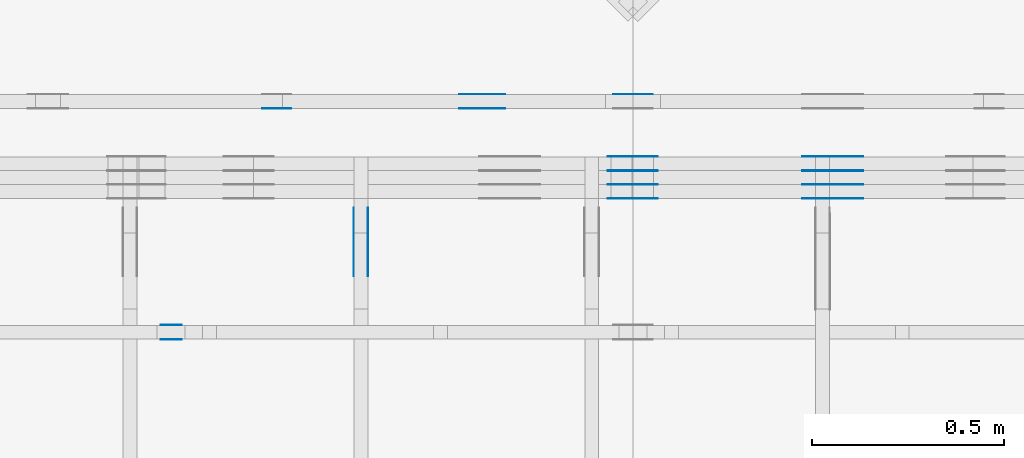
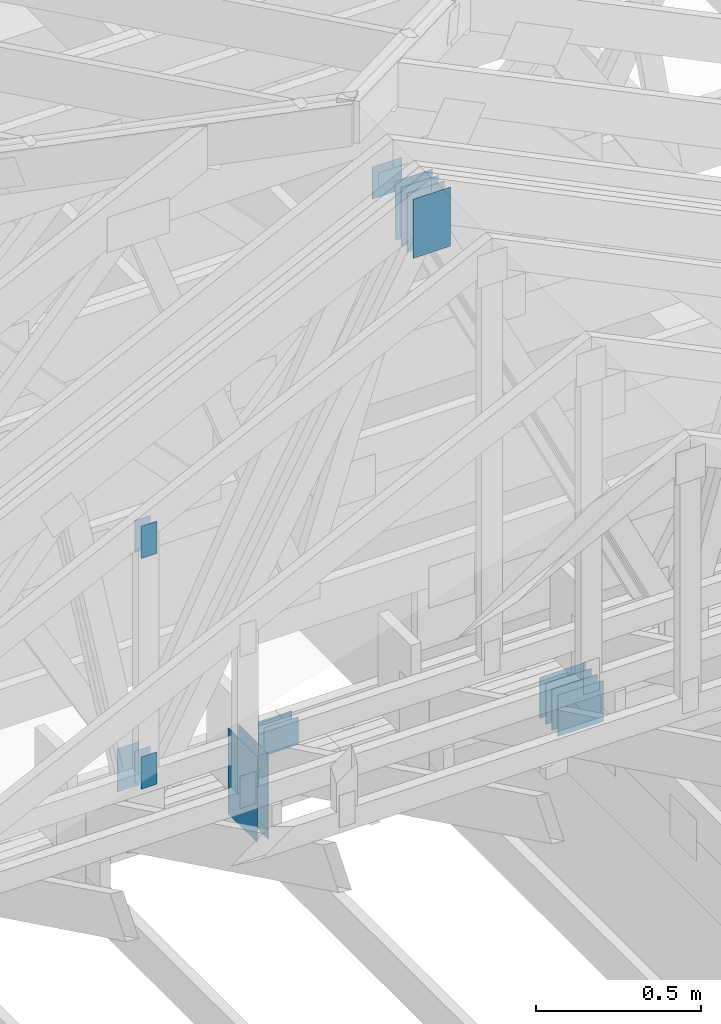
# One storey, part 103 of 159: 22 plates, 4 elements without a shape of their own.
"""IFC2X3 building model written with IfcOpenShell, lengths in millimetres."""

from ifc_helpers import new_model, si_unit, frame, origin, origin_with_axes, origin_2d, place, context, project, spatial, faceted_brep, element, aggregate, save


model = new_model("IFC2X3")

# Units and contexts
model_context = context("Model", 3, precision=1e-05, world=origin())
plan_context = context("Plan", 2, precision=1e-05, world=origin_2d())
ifc_project = project(units=[si_unit("LENGTHUNIT", "METRE", prefix="MILLI"), si_unit("AREAUNIT", "SQUARE_METRE"), si_unit("VOLUMEUNIT", "CUBIC_METRE"), si_unit("SOLIDANGLEUNIT", "STERADIAN"), si_unit("PLANEANGLEUNIT", "RADIAN"), si_unit("MASSUNIT", "GRAM"), si_unit("TIMEUNIT", "SECOND"), si_unit("THERMODYNAMICTEMPERATUREUNIT", "DEGREE_CELSIUS"), si_unit("LUMINOUSINTENSITYUNIT", "LUMEN")], contexts=[model_context, plan_context])

# Site, building, storey
site_placement = place(None, origin_with_axes())
site = spatial("IfcSite", under=ifc_project, at=site_placement, CompositionType="ELEMENT")
building_placement = place(site_placement, origin_with_axes())
building = spatial("IfcBuilding", under=site, at=building_placement, Name="Plan 1", CompositionType="ELEMENT")
storey_placement = place(building_placement, origin_with_axes())
storey = spatial("IfcBuildingStorey", under=building, at=storey_placement, Name="Etasje 1", CompositionType="ELEMENT", Elevation=0.0)

# Assembly, plates
assembly_1_placement = place(storey_placement, frame((10700.012663101485, 8801.999999990367, 0.0), z_axis=(0.0, -1.0, 6.123031769111886e-17), x_axis=(1.0, 0.0, 0.0)))
assembly_1 = element("IfcElementAssembly", 1, at=assembly_1_placement, inside=storey, Name="T8 (1)", AssemblyPlace="FACTORY", PredefinedType="TRUSS")
plate_1_placement = place(assembly_1_placement, frame((4340.0, 146.99999999999977, 0.0), z_axis=(0.0, 0.0, 1.0), x_axis=(1.0, 0.0, 0.0)))
plate_1 = element("IfcPlate", 2, at=plate_1_placement, Name="GNT100S 152x159", context=model_context, shape_type="Brep", body=[
    faceted_brep([(159.0, 152.00000000000023, 1.0), (0.0, 152.00000000000023, 1.0), (0.0, 2.2737367544323206e-13, 1.0), (159.0, 2.2737367544323206e-13, 1.0), (0.0, 152.00000000000023, 0.0), (159.0, 152.00000000000023, 1.9471241025775798e-14), (159.0, 2.2737367544323206e-13, 1.9471241025775798e-14), (0.0, 2.2737367544323206e-13, 0.0), (159.0, -2.92068615386637e-14, 1.788345410772899e-30), (159.0, -2.914563122097258e-14, 1.0), (1.1247455413666031e-32, 6.123031769111886e-17, 1.0), (0.0, 0.0, 0.0), (159.0, 152.0, 0.0), (159.0, 152.0, 1.0), (159.0, 0.0, 1.0), (159.0, 0.0, 0.0), (0.0, 152.0, 0.0), (-3.7491518045553436e-33, 152.0, 1.0), (159.0, 152.0, 1.0), (159.0, 152.0, 0.0), (0.0, 0.0, 0.0), (6.123031769111886e-17, -7.498303609110687e-33, 1.0), (1.8675246895791253e-14, 152.0, 1.0), (1.8614016578100134e-14, 152.0, -1.1397421485848245e-30)], [[[0, 1, 2, 3]], [[4, 5, 6, 7]], [[8, 9, 10, 11]], [[12, 13, 14, 15]], [[16, 17, 18, 19]], [[20, 21, 22, 23]]]),
])
plate_2_placement = place(assembly_1_placement, frame((4340.0, 146.99999999999977, -37.0), z_axis=(0.0, 0.0, 1.0), x_axis=(1.0, 0.0, 0.0)))
plate_2 = element("IfcPlate", 3, at=plate_2_placement, Name="GNT100S 152x159", context=model_context, shape_type="Brep", body=[
    faceted_brep([(159.0, 152.00000000000023, 1.0), (0.0, 152.00000000000023, 1.0), (0.0, 2.2737367544323206e-13, 1.0), (159.0, 2.2737367544323206e-13, 1.0), (0.0, 152.00000000000023, 0.0), (159.0, 152.00000000000023, 1.9471241025775798e-14), (159.0, 2.2737367544323206e-13, 1.9471241025775798e-14), (0.0, 2.2737367544323206e-13, 0.0), (159.0, -2.92068615386637e-14, 1.788345410772899e-30), (159.0, -2.914563122097258e-14, 1.0), (1.1247455413666031e-32, 6.123031769111886e-17, 1.0), (0.0, 0.0, 0.0), (159.0, 152.0, 0.0), (159.0, 152.0, 1.0), (159.0, 0.0, 1.0), (159.0, 0.0, 0.0), (0.0, 152.0, 0.0), (-3.7491518045553436e-33, 152.0, 1.0), (159.0, 152.0, 1.0), (159.0, 152.0, 0.0), (0.0, 0.0, 0.0), (6.123031769111886e-17, -7.498303609110687e-33, 1.0), (1.8675246895791253e-14, 152.0, 1.0), (1.8614016578100134e-14, 152.0, -1.1397421485848245e-30)], [[[0, 1, 2, 3]], [[4, 5, 6, 7]], [[8, 9, 10, 11]], [[12, 13, 14, 15]], [[16, 17, 18, 19]], [[20, 21, 22, 23]]]),
])
plate_3_placement = place(assembly_1_placement, frame((4340.0, 146.99999999999977, -36.0), z_axis=(0.0, 0.0, 1.0), x_axis=(1.0, 0.0, 0.0)))
plate_3 = element("IfcPlate", 4, at=plate_3_placement, Name="GNT100S 152x159", context=model_context, shape_type="Brep", body=[
    faceted_brep([(159.0, 152.00000000000023, 1.0), (0.0, 152.00000000000023, 1.0), (0.0, 2.2737367544323206e-13, 1.0), (159.0, 2.2737367544323206e-13, 1.0), (0.0, 152.00000000000023, 0.0), (159.0, 152.00000000000023, 1.9471241025775798e-14), (159.0, 2.2737367544323206e-13, 1.9471241025775798e-14), (0.0, 2.2737367544323206e-13, 0.0), (159.0, -2.92068615386637e-14, 1.788345410772899e-30), (159.0, -2.914563122097258e-14, 1.0), (1.1247455413666031e-32, 6.123031769111886e-17, 1.0), (0.0, 0.0, 0.0), (159.0, 152.0, 0.0), (159.0, 152.0, 1.0), (159.0, 0.0, 1.0), (159.0, 0.0, 0.0), (0.0, 152.0, 0.0), (-3.7491518045553436e-33, 152.0, 1.0), (159.0, 152.0, 1.0), (159.0, 152.0, 0.0), (0.0, 0.0, 0.0), (6.123031769111886e-17, -7.498303609110687e-33, 1.0), (1.8675246895791253e-14, 152.0, 1.0), (1.8614016578100134e-14, 152.0, -1.1397421485848245e-30)], [[[0, 1, 2, 3]], [[4, 5, 6, 7]], [[8, 9, 10, 11]], [[12, 13, 14, 15]], [[16, 17, 18, 19]], [[20, 21, 22, 23]]]),
])
plate_4_placement = place(assembly_1_placement, frame((4340.0, 146.99999999999977, -73.0), z_axis=(0.0, 0.0, 1.0), x_axis=(1.0, 0.0, 0.0)))
plate_4 = element("IfcPlate", 5, at=plate_4_placement, Name="GNT100S 152x159", context=model_context, shape_type="Brep", body=[
    faceted_brep([(159.0, 152.00000000000023, 1.0), (0.0, 152.00000000000023, 1.0), (0.0, 2.2737367544323206e-13, 1.0), (159.0, 2.2737367544323206e-13, 1.0), (0.0, 152.00000000000023, 0.0), (159.0, 152.00000000000023, 1.9471241025775798e-14), (159.0, 2.2737367544323206e-13, 1.9471241025775798e-14), (0.0, 2.2737367544323206e-13, 0.0), (159.0, -2.92068615386637e-14, 1.788345410772899e-30), (159.0, -2.914563122097258e-14, 1.0), (1.1247455413666031e-32, 6.123031769111886e-17, 1.0), (0.0, 0.0, 0.0), (159.0, 152.0, 0.0), (159.0, 152.0, 1.0), (159.0, 0.0, 1.0), (159.0, 0.0, 0.0), (0.0, 152.0, 0.0), (-3.7491518045553436e-33, 152.0, 1.0), (159.0, 152.0, 1.0), (159.0, 152.0, 0.0), (0.0, 0.0, 0.0), (6.123031769111886e-17, -7.498303609110687e-33, 1.0), (1.8675246895791253e-14, 152.0, 1.0), (1.8614016578100134e-14, 152.0, -1.1397421485848245e-30)], [[[0, 1, 2, 3]], [[4, 5, 6, 7]], [[8, 9, 10, 11]], [[12, 13, 14, 15]], [[16, 17, 18, 19]], [[20, 21, 22, 23]]]),
])
plate_5_placement = place(assembly_1_placement, frame((4340.0, 146.99999999999977, -72.0), z_axis=(0.0, 0.0, 1.0), x_axis=(1.0, 0.0, 0.0)))
plate_5 = element("IfcPlate", 6, at=plate_5_placement, Name="GNT100S 152x159", context=model_context, shape_type="Brep", body=[
    faceted_brep([(159.0, 152.00000000000023, 1.0), (0.0, 152.00000000000023, 1.0), (0.0, 2.2737367544323206e-13, 1.0), (159.0, 2.2737367544323206e-13, 1.0), (0.0, 152.00000000000023, 0.0), (159.0, 152.00000000000023, 1.9471241025775798e-14), (159.0, 2.2737367544323206e-13, 1.9471241025775798e-14), (0.0, 2.2737367544323206e-13, 0.0), (159.0, -2.92068615386637e-14, 1.788345410772899e-30), (159.0, -2.914563122097258e-14, 1.0), (1.1247455413666031e-32, 6.123031769111886e-17, 1.0), (0.0, 0.0, 0.0), (159.0, 152.0, 0.0), (159.0, 152.0, 1.0), (159.0, 0.0, 1.0), (159.0, 0.0, 0.0), (0.0, 152.0, 0.0), (-3.7491518045553436e-33, 152.0, 1.0), (159.0, 152.0, 1.0), (159.0, 152.0, 0.0), (0.0, 0.0, 0.0), (6.123031769111886e-17, -7.498303609110687e-33, 1.0), (1.8675246895791253e-14, 152.0, 1.0), (1.8614016578100134e-14, 152.0, -1.1397421485848245e-30)], [[[0, 1, 2, 3]], [[4, 5, 6, 7]], [[8, 9, 10, 11]], [[12, 13, 14, 15]], [[16, 17, 18, 19]], [[20, 21, 22, 23]]]),
])
plate_6_placement = place(assembly_1_placement, frame((4340.0, 146.99999999999977, -109.0), z_axis=(0.0, 0.0, 1.0), x_axis=(1.0, 0.0, 0.0)))
plate_6 = element("IfcPlate", 7, at=plate_6_placement, Name="GNT100S 152x159", context=model_context, shape_type="Brep", body=[
    faceted_brep([(159.0, 152.00000000000023, 1.0), (0.0, 152.00000000000023, 1.0), (0.0, 2.2737367544323206e-13, 1.0), (159.0, 2.2737367544323206e-13, 1.0), (0.0, 152.00000000000023, 0.0), (159.0, 152.00000000000023, 1.9471241025775798e-14), (159.0, 2.2737367544323206e-13, 1.9471241025775798e-14), (0.0, 2.2737367544323206e-13, 0.0), (159.0, -2.92068615386637e-14, 1.788345410772899e-30), (159.0, -2.914563122097258e-14, 1.0), (1.1247455413666031e-32, 6.123031769111886e-17, 1.0), (0.0, 0.0, 0.0), (159.0, 152.0, 0.0), (159.0, 152.0, 1.0), (159.0, 0.0, 1.0), (159.0, 0.0, 0.0), (0.0, 152.0, 0.0), (-3.7491518045553436e-33, 152.0, 1.0), (159.0, 152.0, 1.0), (159.0, 152.0, 0.0), (0.0, 0.0, 0.0), (6.123031769111886e-17, -7.498303609110687e-33, 1.0), (1.8675246895791253e-14, 152.0, 1.0), (1.8614016578100134e-14, 152.0, -1.1397421485848245e-30)], [[[0, 1, 2, 3]], [[4, 5, 6, 7]], [[8, 9, 10, 11]], [[12, 13, 14, 15]], [[16, 17, 18, 19]], [[20, 21, 22, 23]]]),
])
plate_7_placement = place(assembly_1_placement, frame((3834.999999999998, 2307.9048202130944, 0.0), z_axis=(0.0, 0.0, 1.0), x_axis=(6.123031769111886e-17, -1.0, 0.0)))
plate_7 = element("IfcPlate", 8, at=plate_7_placement, Name="GNT100S 130x218", context=model_context, shape_type="Brep", body=[
    faceted_brep([(218.00003505684435, 130.00000000000182, 1.0), (3.505684435367584e-05, 130.00000000000182, 1.0), (3.505684435367584e-05, 1.8189894035458565e-12, 1.0), (218.00003505684435, 1.8189894035458565e-12, 1.0), (3.505684435367584e-05, 130.00000000000182, 4.293083434047357e-21), (218.00003505684435, 130.00000000000182, 2.6696422806411258e-14), (218.00003505684435, 1.8189894035458565e-12, 2.6696422806411258e-14), (3.505684435367584e-05, 1.8189894035458565e-12, 4.293083434047357e-21), (218.0, -4.0044627769991736e-14, 2.4519452801791947e-30), (218.0, -3.998339745230062e-14, 1.0), (1.1247455413666031e-32, 6.123031769111886e-17, 1.0), (0.0, 0.0, 0.0), (218.0, 130.0, 0.0), (218.0, 130.0, 1.0), (218.0, 0.0, 1.0), (218.0, 0.0, 0.0), (0.0, 130.0, 0.0), (-3.7491518045553436e-33, 130.0, 1.0), (218.0, 130.0, 1.0), (218.0, 130.0, -1.5777218104420236e-30), (0.0, 0.0, 0.0), (6.123031769111886e-17, -7.498303609110687e-33, 1.0), (1.5981112917382023e-14, 130.0, 1.0), (1.5919882599690904e-14, 130.0, -9.747794691843893e-31)], [[[0, 1, 2, 3]], [[4, 5, 6, 7]], [[8, 9, 10, 11]], [[12, 13, 14, 15]], [[16, 17, 18, 19]], [[20, 21, 22, 23]]]),
])
plate_8_placement = place(assembly_1_placement, frame((3834.999999999998, 2307.9048202130944, -37.0), z_axis=(0.0, 0.0, 1.0), x_axis=(6.123031769111886e-17, -1.0, 0.0)))
plate_8 = element("IfcPlate", 9, at=plate_8_placement, Name="GNT100S 130x218", context=model_context, shape_type="Brep", body=[
    faceted_brep([(218.00003505684435, 130.00000000000182, 1.0), (3.505684435367584e-05, 130.00000000000182, 1.0), (3.505684435367584e-05, 1.8189894035458565e-12, 1.0), (218.00003505684435, 1.8189894035458565e-12, 1.0), (3.505684435367584e-05, 130.00000000000182, 4.293083434047357e-21), (218.00003505684435, 130.00000000000182, 2.6696422806411258e-14), (218.00003505684435, 1.8189894035458565e-12, 2.6696422806411258e-14), (3.505684435367584e-05, 1.8189894035458565e-12, 4.293083434047357e-21), (218.0, -4.0044627769991736e-14, 2.4519452801791947e-30), (218.0, -3.998339745230062e-14, 1.0), (1.1247455413666031e-32, 6.123031769111886e-17, 1.0), (0.0, 0.0, 0.0), (218.0, 130.0, 0.0), (218.0, 130.0, 1.0), (218.0, 0.0, 1.0), (218.0, 0.0, 0.0), (0.0, 130.0, 0.0), (-3.7491518045553436e-33, 130.0, 1.0), (218.0, 130.0, 1.0), (218.0, 130.0, -1.5777218104420236e-30), (0.0, 0.0, 0.0), (6.123031769111886e-17, -7.498303609110687e-33, 1.0), (1.5981112917382023e-14, 130.0, 1.0), (1.5919882599690904e-14, 130.0, -9.747794691843893e-31)], [[[0, 1, 2, 3]], [[4, 5, 6, 7]], [[8, 9, 10, 11]], [[12, 13, 14, 15]], [[16, 17, 18, 19]], [[20, 21, 22, 23]]]),
])
plate_9_placement = place(assembly_1_placement, frame((3834.999999999998, 2307.9048202130944, -36.0), z_axis=(0.0, 0.0, 1.0), x_axis=(6.123031769111886e-17, -1.0, 0.0)))
plate_9 = element("IfcPlate", 10, at=plate_9_placement, Name="GNT100S 130x218", context=model_context, shape_type="Brep", body=[
    faceted_brep([(218.00003505684435, 130.00000000000182, 1.0), (3.505684435367584e-05, 130.00000000000182, 1.0), (3.505684435367584e-05, 1.8189894035458565e-12, 1.0), (218.00003505684435, 1.8189894035458565e-12, 1.0), (3.505684435367584e-05, 130.00000000000182, 4.293083434047357e-21), (218.00003505684435, 130.00000000000182, 2.6696422806411258e-14), (218.00003505684435, 1.8189894035458565e-12, 2.6696422806411258e-14), (3.505684435367584e-05, 1.8189894035458565e-12, 4.293083434047357e-21), (218.0, -4.0044627769991736e-14, 2.4519452801791947e-30), (218.0, -3.998339745230062e-14, 1.0), (1.1247455413666031e-32, 6.123031769111886e-17, 1.0), (0.0, 0.0, 0.0), (218.0, 130.0, 0.0), (218.0, 130.0, 1.0), (218.0, 0.0, 1.0), (218.0, 0.0, 0.0), (0.0, 130.0, 0.0), (-3.7491518045553436e-33, 130.0, 1.0), (218.0, 130.0, 1.0), (218.0, 130.0, -1.5777218104420236e-30), (0.0, 0.0, 0.0), (6.123031769111886e-17, -7.498303609110687e-33, 1.0), (1.5981112917382023e-14, 130.0, 1.0), (1.5919882599690904e-14, 130.0, -9.747794691843893e-31)], [[[0, 1, 2, 3]], [[4, 5, 6, 7]], [[8, 9, 10, 11]], [[12, 13, 14, 15]], [[16, 17, 18, 19]], [[20, 21, 22, 23]]]),
])
plate_10_placement = place(assembly_1_placement, frame((3834.999999999998, 2307.9048202130944, -73.0), z_axis=(0.0, 0.0, 1.0), x_axis=(6.123031769111886e-17, -1.0, 0.0)))
plate_10 = element("IfcPlate", 11, at=plate_10_placement, Name="GNT100S 130x218", context=model_context, shape_type="Brep", body=[
    faceted_brep([(218.00003505684435, 130.00000000000182, 1.0), (3.505684435367584e-05, 130.00000000000182, 1.0), (3.505684435367584e-05, 1.8189894035458565e-12, 1.0), (218.00003505684435, 1.8189894035458565e-12, 1.0), (3.505684435367584e-05, 130.00000000000182, 4.293083434047357e-21), (218.00003505684435, 130.00000000000182, 2.6696422806411258e-14), (218.00003505684435, 1.8189894035458565e-12, 2.6696422806411258e-14), (3.505684435367584e-05, 1.8189894035458565e-12, 4.293083434047357e-21), (218.0, -4.0044627769991736e-14, 2.4519452801791947e-30), (218.0, -3.998339745230062e-14, 1.0), (1.1247455413666031e-32, 6.123031769111886e-17, 1.0), (0.0, 0.0, 0.0), (218.0, 130.0, 0.0), (218.0, 130.0, 1.0), (218.0, 0.0, 1.0), (218.0, 0.0, 0.0), (0.0, 130.0, 0.0), (-3.7491518045553436e-33, 130.0, 1.0), (218.0, 130.0, 1.0), (218.0, 130.0, -1.5777218104420236e-30), (0.0, 0.0, 0.0), (6.123031769111886e-17, -7.498303609110687e-33, 1.0), (1.5981112917382023e-14, 130.0, 1.0), (1.5919882599690904e-14, 130.0, -9.747794691843893e-31)], [[[0, 1, 2, 3]], [[4, 5, 6, 7]], [[8, 9, 10, 11]], [[12, 13, 14, 15]], [[16, 17, 18, 19]], [[20, 21, 22, 23]]]),
])
plate_11_placement = place(assembly_1_placement, frame((3834.999999999998, 2307.9048202130944, -72.0), z_axis=(0.0, 0.0, 1.0), x_axis=(6.123031769111886e-17, -1.0, 0.0)))
plate_11 = element("IfcPlate", 12, at=plate_11_placement, Name="GNT100S 130x218", context=model_context, shape_type="Brep", body=[
    faceted_brep([(218.00003505684435, 130.00000000000182, 1.0), (3.505684435367584e-05, 130.00000000000182, 1.0), (3.505684435367584e-05, 1.8189894035458565e-12, 1.0), (218.00003505684435, 1.8189894035458565e-12, 1.0), (3.505684435367584e-05, 130.00000000000182, 4.293083434047357e-21), (218.00003505684435, 130.00000000000182, 2.6696422806411258e-14), (218.00003505684435, 1.8189894035458565e-12, 2.6696422806411258e-14), (3.505684435367584e-05, 1.8189894035458565e-12, 4.293083434047357e-21), (218.0, -4.0044627769991736e-14, 2.4519452801791947e-30), (218.0, -3.998339745230062e-14, 1.0), (1.1247455413666031e-32, 6.123031769111886e-17, 1.0), (0.0, 0.0, 0.0), (218.0, 130.0, 0.0), (218.0, 130.0, 1.0), (218.0, 0.0, 1.0), (218.0, 0.0, 0.0), (0.0, 130.0, 0.0), (-3.7491518045553436e-33, 130.0, 1.0), (218.0, 130.0, 1.0), (218.0, 130.0, -1.5777218104420236e-30), (0.0, 0.0, 0.0), (6.123031769111886e-17, -7.498303609110687e-33, 1.0), (1.5981112917382023e-14, 130.0, 1.0), (1.5919882599690904e-14, 130.0, -9.747794691843893e-31)], [[[0, 1, 2, 3]], [[4, 5, 6, 7]], [[8, 9, 10, 11]], [[12, 13, 14, 15]], [[16, 17, 18, 19]], [[20, 21, 22, 23]]]),
])
plate_12_placement = place(assembly_1_placement, frame((3834.999999999998, 2307.9048202130944, -109.0), z_axis=(0.0, 0.0, 1.0), x_axis=(6.123031769111886e-17, -1.0, 0.0)))
plate_12 = element("IfcPlate", 13, at=plate_12_placement, Name="GNT100S 130x218", context=model_context, shape_type="Brep", body=[
    faceted_brep([(218.00003505684435, 130.00000000000182, 1.0), (3.505684435367584e-05, 130.00000000000182, 1.0), (3.505684435367584e-05, 1.8189894035458565e-12, 1.0), (218.00003505684435, 1.8189894035458565e-12, 1.0), (3.505684435367584e-05, 130.00000000000182, 4.293083434047357e-21), (218.00003505684435, 130.00000000000182, 2.6696422806411258e-14), (218.00003505684435, 1.8189894035458565e-12, 2.6696422806411258e-14), (3.505684435367584e-05, 1.8189894035458565e-12, 4.293083434047357e-21), (218.0, -4.0044627769991736e-14, 2.4519452801791947e-30), (218.0, -3.998339745230062e-14, 1.0), (1.1247455413666031e-32, 6.123031769111886e-17, 1.0), (0.0, 0.0, 0.0), (218.0, 130.0, 0.0), (218.0, 130.0, 1.0), (218.0, 0.0, 1.0), (218.0, 0.0, 0.0), (0.0, 130.0, 0.0), (-3.7491518045553436e-33, 130.0, 1.0), (218.0, 130.0, 1.0), (218.0, 130.0, -1.5777218104420236e-30), (0.0, 0.0, 0.0), (6.123031769111886e-17, -7.498303609110687e-33, 1.0), (1.5981112917382023e-14, 130.0, 1.0), (1.5919882599690904e-14, 130.0, -9.747794691843893e-31)], [[[0, 1, 2, 3]], [[4, 5, 6, 7]], [[8, 9, 10, 11]], [[12, 13, 14, 15]], [[16, 17, 18, 19]], [[20, 21, 22, 23]]]),
])
aggregate(assembly_1, [plate_1, plate_2, plate_3, plate_4, plate_5, plate_6, plate_7, plate_8, plate_9, plate_10, plate_11, plate_12])

assembly_2_placement = place(storey_placement, frame((10000.012663278096, 9072.000080051337, 1.1021457184401395e-15), z_axis=(9.811600543477555e-09, 1.0, 6.123031769111886e-17), x_axis=(-1.0, 9.811600543477555e-09, 0.0)))
assembly_2 = element("IfcElementAssembly", 14, at=assembly_2_placement, inside=storey, Name="T9 (79)", AssemblyPlace="FACTORY", PredefinedType="TRUSS")
plate_13_placement = place(assembly_2_placement, frame((-4651.5, 2258.4048202130944, 0.0), z_axis=(0.0, 0.0, 1.0), x_axis=(6.123031769111886e-17, -1.0, 0.0)))
plate_13 = element("IfcPlate", 15, at=plate_13_placement, Name="GNT100S 103x119", context=model_context, shape_type="Brep", body=[
    faceted_brep([(119.00003505684435, 103.0, 1.0), (3.505684435367584e-05, 103.0, 1.0), (3.505684435367584e-05, 0.0, 1.0), (119.00003505684435, 0.0, 1.0), (3.505684435367584e-05, 103.0, 4.293083434047357e-21), (119.00003505684435, 103.0, 1.4572819903569723e-14), (119.00003505684435, 0.0, 1.4572819903569723e-14), (3.505684435367584e-05, 0.0, 4.293083434047357e-21), (119.0, 1.797130180130127e-12, 1.3384471942262577e-30), (119.0, 1.7971914104478182e-12, 1.0), (1.1247455413666031e-32, 1.8190506338635476e-12, 1.0), (0.0, 1.8189894035458565e-12, 0.0), (119.0, 103.00000000000182, 0.0), (119.0, 103.00000000000182, 1.0), (119.0, 1.8189894035458565e-12, 1.0), (119.0, 1.8189894035458565e-12, 0.0), (0.0, 103.00000000000182, 0.0), (-3.7491518045553436e-33, 103.00000000000182, 1.0), (119.0, 103.0000000000018, 1.0), (119.0, 103.0000000000018, -7.888609052210118e-31), (2.227545981117832e-28, 1.8189894035458565e-12, -1.3639334809541992e-44), (6.123031769134162e-17, 1.8189894035458565e-12, 1.0), (1.2674675762061827e-14, 103.00000000000182, 1.0), (1.2613445444370708e-14, 103.00000000000182, -7.7232527173841444e-31)], [[[0, 1, 2, 3]], [[4, 5, 6, 7]], [[8, 9, 10, 11]], [[12, 13, 14, 15]], [[16, 17, 18, 19]], [[20, 21, 22, 23]]]),
])
plate_14_placement = place(assembly_2_placement, frame((-3636.319824218732, 291.5, -37.0), z_axis=(0.0, 0.0, 1.0), x_axis=(6.123031769111886e-17, 1.0, 0.0)))
plate_14 = element("IfcPlate", 16, at=plate_14_placement, Name="GNT100S 76x159", context=model_context, shape_type="Brep", body=[
    faceted_brep([(159.0, 76.00000000001819, 1.0), (0.0, 76.00000000001819, 1.0), (0.0, 1.8189894035458565e-11, 1.0), (159.0, 1.8189894035458565e-11, 1.0), (0.0, 76.00000000001819, 0.0), (159.0, 76.00000000001819, 1.9471241025775798e-14), (159.0, 1.8189894035458565e-11, 1.9471241025775798e-14), (0.0, 1.8189894035458565e-11, 0.0), (159.00000000000045, -2.920686153866378e-14, 1.788345410772904e-30), (159.00000000000045, -2.914563122097266e-14, 1.0), (4.547473508864641e-13, 6.123031769103533e-17, 1.0), (4.547473508864641e-13, -8.35329742919187e-29, 5.114750553578247e-45), (159.00000000000045, 76.0, 0.0), (159.00000000000045, 76.0, 1.0), (159.00000000000045, 0.0, 1.0), (159.00000000000045, 0.0, 0.0), (4.547473508864641e-13, 76.0, 0.0), (4.547473508864641e-13, 76.0, 1.0), (159.00000000000045, 75.99999999999999, 1.0), (159.00000000000045, 75.99999999999999, -7.888609052210118e-31), (4.547473508864641e-13, 0.0, 0.0), (4.548085812041552e-13, -7.498303609110687e-33, 1.0), (4.641155894932053e-13, 76.0, 1.0), (4.640543591755142e-13, 76.0, -5.698710742924122e-31)], [[[0, 1, 2, 3]], [[4, 5, 6, 7]], [[8, 9, 10, 11]], [[12, 13, 14, 15]], [[16, 17, 18, 19]], [[20, 21, 22, 23]]]),
])
plate_15_placement = place(assembly_2_placement, frame((-4149.3187043163925, 348.5000000000005, 0.0), z_axis=(0.0, 0.0, 1.0), x_axis=(-1.0, 1.2246063538223773e-16, 0.0)))
plate_15 = element("IfcPlate", 17, at=plate_15_placement, Name="GNT100S 103x119", context=model_context, shape_type="Brep", body=[
    faceted_brep([(119.00014333985746, 103.00000000000051, 1.0), (0.0001433398574590683, 103.00000000000051, 1.0), (0.0001433398574590683, 5.115907697472721e-13, 1.0), (119.00014333985746, 5.115907697472721e-13, 1.0), (0.0001433398574590683, 103.00000000000051, 1.755349002003689e-20), (119.00014333985746, 103.00000000000051, 1.457283316397631e-14), (119.00014333985746, 5.115907697472721e-13, 1.457283316397631e-14), (0.0001433398574590683, 5.115907697472721e-13, 1.755349002003689e-20), (119.0, -2.1859223415729434e-14, 1.3384471942262577e-30), (119.0, -2.1797993098038315e-14, 1.0), (1.1247455413666031e-32, 6.123031769111886e-17, 1.0), (0.0, 0.0, 0.0), (119.0, 103.0, 0.0), (119.0, 103.0, 1.0), (119.0, 0.0, 1.0), (119.0, 0.0, 0.0), (0.0, 103.0, 0.0), (-3.7491518045553436e-33, 103.0, 1.0), (119.0, 102.99999999999999, 1.0), (119.0, 102.99999999999999, -7.888609052210118e-31), (0.0, 0.0, 0.0), (6.123031769111886e-17, -7.498303609110687e-33, 1.0), (1.2674675762061605e-14, 103.0, 1.0), (1.2613445444370486e-14, 103.0, -7.723252717384008e-31)], [[[0, 1, 2, 3]], [[4, 5, 6, 7]], [[8, 9, 10, 11]], [[12, 13, 14, 15]], [[16, 17, 18, 19]], [[20, 21, 22, 23]]]),
])
plate_16_placement = place(assembly_2_placement, frame((-4149.3187043163925, 348.5000000000005, -37.0), z_axis=(0.0, 0.0, 1.0), x_axis=(-1.0, 1.2246063538223773e-16, 0.0)))
plate_16 = element("IfcPlate", 18, at=plate_16_placement, Name="GNT100S 103x119", context=model_context, shape_type="Brep", body=[
    faceted_brep([(119.00014333985746, 103.00000000000051, 1.0), (0.0001433398574590683, 103.00000000000051, 1.0), (0.0001433398574590683, 5.115907697472721e-13, 1.0), (119.00014333985746, 5.115907697472721e-13, 1.0), (0.0001433398574590683, 103.00000000000051, 1.755349002003689e-20), (119.00014333985746, 103.00000000000051, 1.457283316397631e-14), (119.00014333985746, 5.115907697472721e-13, 1.457283316397631e-14), (0.0001433398574590683, 5.115907697472721e-13, 1.755349002003689e-20), (119.0, -2.1859223415729434e-14, 1.3384471942262577e-30), (119.0, -2.1797993098038315e-14, 1.0), (1.1247455413666031e-32, 6.123031769111886e-17, 1.0), (0.0, 0.0, 0.0), (119.0, 103.0, 0.0), (119.0, 103.0, 1.0), (119.0, 0.0, 1.0), (119.0, 0.0, 0.0), (0.0, 103.0, 0.0), (-3.7491518045553436e-33, 103.0, 1.0), (119.0, 102.99999999999999, 1.0), (119.0, 102.99999999999999, -7.888609052210118e-31), (0.0, 0.0, 0.0), (6.123031769111886e-17, -7.498303609110687e-33, 1.0), (1.2674675762061605e-14, 103.0, 1.0), (1.2613445444370486e-14, 103.0, -7.723252717384008e-31)], [[[0, 1, 2, 3]], [[4, 5, 6, 7]], [[8, 9, 10, 11]], [[12, 13, 14, 15]], [[16, 17, 18, 19]], [[20, 21, 22, 23]]]),
])
aggregate(assembly_2, [plate_13, plate_14, plate_15, plate_16])

assembly_3_placement = place(storey_placement, frame((13875.022261404752, -699.9989301294836, 1.1021457184401395e-15), z_axis=(-1.0, 1.836909530733566e-16, 6.123031769111886e-17), x_axis=(-1.836909530733566e-16, -1.0, 0.0)))
assembly_3 = element("IfcElementAssembly", 19, at=assembly_3_placement, inside=storey, Name="T6 (101)", AssemblyPlace="FACTORY", PredefinedType="TRUSS")
plate_17_placement = place(assembly_3_placement, frame((-9477.154435624892, 601.947714222237, 0.0), z_axis=(0.0, 0.0, 1.0), x_axis=(2.6073089813474087e-12, -1.0, 0.0)))
plate_17 = element("IfcPlate", 20, at=plate_17_placement, Name="GNT100S 178x317", context=model_context, shape_type="Brep", body=[
    faceted_brep([(316.9999908340292, 178.00013874989236, 1.0), (2.1351607301767217e-05, 178.00013874989236, 1.0), (2.1351143232095637e-05, 0.00013874989235773683, 1.0), (316.99999083356505, 0.00013874989235773683, 1.0), (2.1351607301767217e-05, 178.00013874989236, 2.61473139660644e-21), (316.9999908340292, 178.00013874989236, 3.882002029369875e-14), (316.99999083356505, 0.0001387490647175582, 3.882002029364191e-14), (2.1351143232095637e-05, 0.0001387490647175582, 2.6146745663395966e-21), (317.00000000000006, -2.1010854189297505e-13, 1.286501276972462e-29), (317.00000000000006, -2.1004731157528393e-13, 1.0), (1.1368683772161603e-13, 1.8190506338635476e-12, 1.0), (1.1368683772161603e-13, 1.8189894035458565e-12, 0.0), (317.00000000000006, 178.0, 0.0), (317.00000000000006, 178.0, 1.0), (317.00000000000006, 0.0, 1.0), (317.00000000000006, 0.0, 0.0), (0.0, 178.00000000000182, 0.0), (0.0, 178.00000000000182, 1.0), (317.00000000000006, 177.99999999999997, 1.0), (317.00000000000006, 177.99999999999997, -1.5777218104420236e-30), (1.1368683772161664e-13, 1.8189894035458565e-12, -3.6433760072445244e-44), (1.1374806803930775e-13, 1.8189894035458565e-12, 1.0), (5.6498181784034924e-14, 178.00000000000182, 1.0), (5.6436951466343805e-14, 178.00000000000182, -3.455652467802488e-30)], [[[0, 1, 2, 3]], [[4, 5, 6, 7]], [[8, 9, 10, 11]], [[12, 13, 14, 15]], [[16, 17, 18, 19]], [[20, 21, 22, 23]]]),
])
plate_18_placement = place(assembly_3_placement, frame((-9477.154435624892, 601.947714222237, -37.0), z_axis=(0.0, 0.0, 1.0), x_axis=(2.6073089813474087e-12, -1.0, 0.0)))
plate_18 = element("IfcPlate", 21, at=plate_18_placement, Name="GNT100S 178x317", context=model_context, shape_type="Brep", body=[
    faceted_brep([(316.9999908340292, 178.00013874989236, 1.0), (2.1351607301767217e-05, 178.00013874989236, 1.0), (2.1351143232095637e-05, 0.00013874989235773683, 1.0), (316.99999083356505, 0.00013874989235773683, 1.0), (2.1351607301767217e-05, 178.00013874989236, 2.61473139660644e-21), (316.9999908340292, 178.00013874989236, 3.882002029369875e-14), (316.99999083356505, 0.0001387490647175582, 3.882002029364191e-14), (2.1351143232095637e-05, 0.0001387490647175582, 2.6146745663395966e-21), (317.00000000000006, -2.1010854189297505e-13, 1.286501276972462e-29), (317.00000000000006, -2.1004731157528393e-13, 1.0), (1.1368683772161603e-13, 1.8190506338635476e-12, 1.0), (1.1368683772161603e-13, 1.8189894035458565e-12, 0.0), (317.00000000000006, 178.0, 0.0), (317.00000000000006, 178.0, 1.0), (317.00000000000006, 0.0, 1.0), (317.00000000000006, 0.0, 0.0), (0.0, 178.00000000000182, 0.0), (0.0, 178.00000000000182, 1.0), (317.00000000000006, 177.99999999999997, 1.0), (317.00000000000006, 177.99999999999997, -1.5777218104420236e-30), (1.1368683772161664e-13, 1.8189894035458565e-12, -3.6433760072445244e-44), (1.1374806803930775e-13, 1.8189894035458565e-12, 1.0), (5.6498181784034924e-14, 178.00000000000182, 1.0), (5.6436951466343805e-14, 178.00000000000182, -3.455652467802488e-30)], [[[0, 1, 2, 3]], [[4, 5, 6, 7]], [[8, 9, 10, 11]], [[12, 13, 14, 15]], [[16, 17, 18, 19]], [[20, 21, 22, 23]]]),
])
aggregate(assembly_3, [plate_17, plate_18])

assembly_4_placement = place(storey_placement, frame((11246.01259527543, 8436.00006782605, 727.7147722720857), z_axis=(0.0, -1.0, 6.123031769111886e-17), x_axis=(1.0, 0.0, 0.0)))
assembly_4 = element("IfcElementAssembly", 22, at=assembly_4_placement, inside=storey, Name="Tr1 (1)", AssemblyPlace="FACTORY", PredefinedType="TRUSS")
plate_19_placement = place(assembly_4_placement, frame((2126.5, 1001.0410386863377, 0.0), z_axis=(0.0, 0.0, 1.0), x_axis=(6.123031769111886e-17, -1.0, 0.0)))
plate_19 = element("IfcPlate", 23, at=plate_19_placement, Name="GNT100S 55x119", context=model_context, shape_type="Brep", body=[
    faceted_brep([(119.00002306133774, 55.0, 1.0), (2.306133774254704e-05, 55.0, 1.0), (2.306133774254704e-05, 0.0, 1.0), (119.00002306133774, 0.0, 1.0), (2.306133774254704e-05, 55.0, 2.8241060727166902e-21), (119.00002306133774, 55.0, 1.4572818434592364e-14), (119.00002306133774, 0.0, 1.4572818434592364e-14), (2.306133774254704e-05, 0.0, 2.8241060727166902e-21), (119.0, 6.782605394252235e-05, 1.3384468320270608e-30), (119.0, 6.782605394258358e-05, 1.0), (1.1247455413666031e-32, 6.78260539644428e-05, 1.0), (0.0, 6.782605396438157e-05, 0.0), (119.0, 55.000067826053964, 0.0), (119.0, 55.000067826053964, 1.0), (119.0, 6.782605396438157e-05, 1.0), (119.0, 6.782605396438157e-05, 0.0), (2.4308653429145085e-63, 55.000067826053964, 0.0), (-3.7491518045553436e-33, 55.000067826053964, 1.0), (119.0, 55.00006782605396, 1.0), (119.0, 55.00006782605396, -3.944304526105059e-31), (8.306021663948111e-21, 6.782605396438157e-05, -5.085803452328586e-37), (6.123862371278281e-17, 6.782605396438157e-05, 1.0), (6.796573569735858e-15, 55.000067826053964, 1.0), (6.735343252044739e-15, 55.000067826053964, -4.12407207081433e-31)], [[[0, 1, 2, 3]], [[4, 5, 6, 7]], [[8, 9, 10, 11]], [[12, 13, 14, 15]], [[16, 17, 18, 19]], [[20, 21, 22, 23]]]),
])
plate_20_placement = place(assembly_4_placement, frame((2126.5, 1001.0410386863377, -37.0), z_axis=(0.0, 0.0, 1.0), x_axis=(6.123031769111886e-17, -1.0, 0.0)))
plate_20 = element("IfcPlate", 24, at=plate_20_placement, Name="GNT100S 55x119", context=model_context, shape_type="Brep", body=[
    faceted_brep([(119.00002306133774, 55.0, 1.0), (2.306133774254704e-05, 55.0, 1.0), (2.306133774254704e-05, 0.0, 1.0), (119.00002306133774, 0.0, 1.0), (2.306133774254704e-05, 55.0, 2.8241060727166902e-21), (119.00002306133774, 55.0, 1.4572818434592364e-14), (119.00002306133774, 0.0, 1.4572818434592364e-14), (2.306133774254704e-05, 0.0, 2.8241060727166902e-21), (119.0, 6.782605394252235e-05, 1.3384468320270608e-30), (119.0, 6.782605394258358e-05, 1.0), (1.1247455413666031e-32, 6.78260539644428e-05, 1.0), (0.0, 6.782605396438157e-05, 0.0), (119.0, 55.000067826053964, 0.0), (119.0, 55.000067826053964, 1.0), (119.0, 6.782605396438157e-05, 1.0), (119.0, 6.782605396438157e-05, 0.0), (2.4308653429145085e-63, 55.000067826053964, 0.0), (-3.7491518045553436e-33, 55.000067826053964, 1.0), (119.0, 55.00006782605396, 1.0), (119.0, 55.00006782605396, -3.944304526105059e-31), (8.306021663948111e-21, 6.782605396438157e-05, -5.085803452328586e-37), (6.123862371278281e-17, 6.782605396438157e-05, 1.0), (6.796573569735858e-15, 55.000067826053964, 1.0), (6.735343252044739e-15, 55.000067826053964, -4.12407207081433e-31)], [[[0, 1, 2, 3]], [[4, 5, 6, 7]], [[8, 9, 10, 11]], [[12, 13, 14, 15]], [[16, 17, 18, 19]], [[20, 21, 22, 23]]]),
])
plate_21_placement = place(assembly_4_placement, frame((2181.5000678260535, 29.720829010009762, 0.0), z_axis=(0.0, 0.0, 1.0), x_axis=(6.123031769111886e-17, 1.0, 0.0)))
plate_21 = element("IfcPlate", 25, at=plate_21_placement, Name="GNT100S 55x119", context=model_context, shape_type="Brep", body=[
    faceted_brep([(118.99999618530275, 55.00006782605351, 1.0), (0.0, 55.00006782605351, 1.0), (3.552713678800501e-15, 6.782605350963422e-05, 1.0), (118.99999618530275, 6.782605350963422e-05, 1.0), (0.0, 55.00006782605351, 0.0), (118.99999618530275, 55.00006782605351, 1.4572815143336042e-14), (118.99999618530275, 6.782605350963422e-05, 1.4572815143336042e-14), (3.552713678800501e-15, 6.782605350963422e-05, 4.350675744370766e-31), (119.00000002031472, -2.1859223419461065e-14, 1.3384471944547466e-30), (119.00000002031472, -2.1797993101769946e-14, 1.0), (2.0314704585189247e-08, 6.123031395949142e-17, 1.0), (2.0314704585189247e-08, -3.7316274466571e-24, 2.2848873406371294e-40), (119.00000002031472, 55.0, 0.0), (119.00000002031472, 55.0, 1.0), (119.00000002031472, 0.0, 1.0), (119.00000002031472, 0.0, 0.0), (2.0314704585189247e-08, 55.0, 0.0), (2.0314704585189247e-08, 55.0, 1.0), (119.00000002031472, 54.99999999999999, 1.0), (119.00000002031472, 54.99999999999999, -3.944304526105059e-31), (2.0314704585189247e-08, 0.0, 0.0), (2.0314704646419565e-08, -7.498303609110687e-33, 1.0), (2.031471138175451e-08, 55.0, 1.0), (2.0314711320524193e-08, 55.0, -4.124066985010878e-31)], [[[0, 1, 2, 3]], [[4, 5, 6, 7]], [[8, 9, 10, 11]], [[12, 13, 14, 15]], [[16, 17, 18, 19]], [[20, 21, 22, 23]]]),
])
plate_22_placement = place(assembly_4_placement, frame((2181.5000678260535, 29.720829010009762, -37.0), z_axis=(0.0, 0.0, 1.0), x_axis=(6.123031769111886e-17, 1.0, 0.0)))
plate_22 = element("IfcPlate", 26, at=plate_22_placement, Name="GNT100S 55x119", context=model_context, shape_type="Brep", body=[
    faceted_brep([(118.99999618530275, 55.00006782605351, 1.0), (0.0, 55.00006782605351, 1.0), (3.552713678800501e-15, 6.782605350963422e-05, 1.0), (118.99999618530275, 6.782605350963422e-05, 1.0), (0.0, 55.00006782605351, 0.0), (118.99999618530275, 55.00006782605351, 1.4572815143336042e-14), (118.99999618530275, 6.782605350963422e-05, 1.4572815143336042e-14), (3.552713678800501e-15, 6.782605350963422e-05, 4.350675744370766e-31), (119.00000002031472, -2.1859223419461065e-14, 1.3384471944547466e-30), (119.00000002031472, -2.1797993101769946e-14, 1.0), (2.0314704585189247e-08, 6.123031395949142e-17, 1.0), (2.0314704585189247e-08, -3.7316274466571e-24, 2.2848873406371294e-40), (119.00000002031472, 55.0, 0.0), (119.00000002031472, 55.0, 1.0), (119.00000002031472, 0.0, 1.0), (119.00000002031472, 0.0, 0.0), (2.0314704585189247e-08, 55.0, 0.0), (2.0314704585189247e-08, 55.0, 1.0), (119.00000002031472, 54.99999999999999, 1.0), (119.00000002031472, 54.99999999999999, -3.944304526105059e-31), (2.0314704585189247e-08, 0.0, 0.0), (2.0314704646419565e-08, -7.498303609110687e-33, 1.0), (2.031471138175451e-08, 55.0, 1.0), (2.0314711320524193e-08, 55.0, -4.124066985010878e-31)], [[[0, 1, 2, 3]], [[4, 5, 6, 7]], [[8, 9, 10, 11]], [[12, 13, 14, 15]], [[16, 17, 18, 19]], [[20, 21, 22, 23]]]),
])
aggregate(assembly_4, [plate_19, plate_20, plate_21, plate_22])

save(model, "model.ifc")
